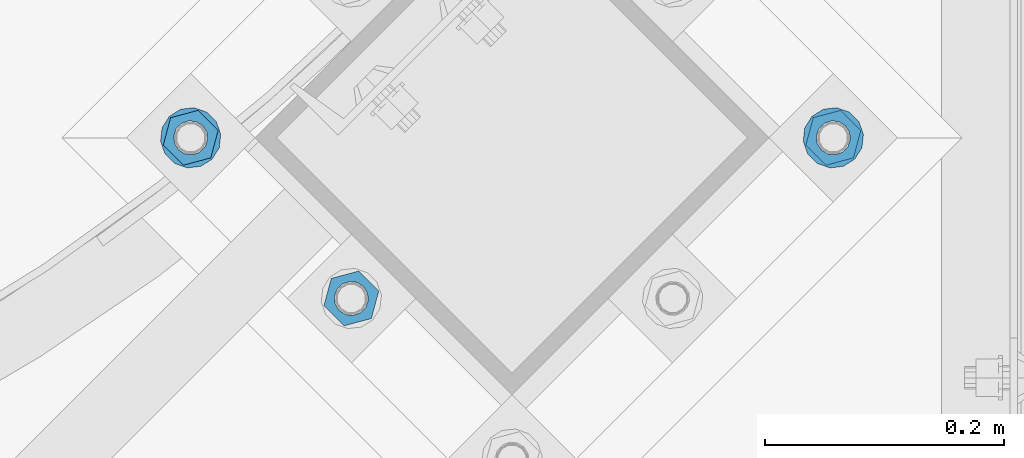
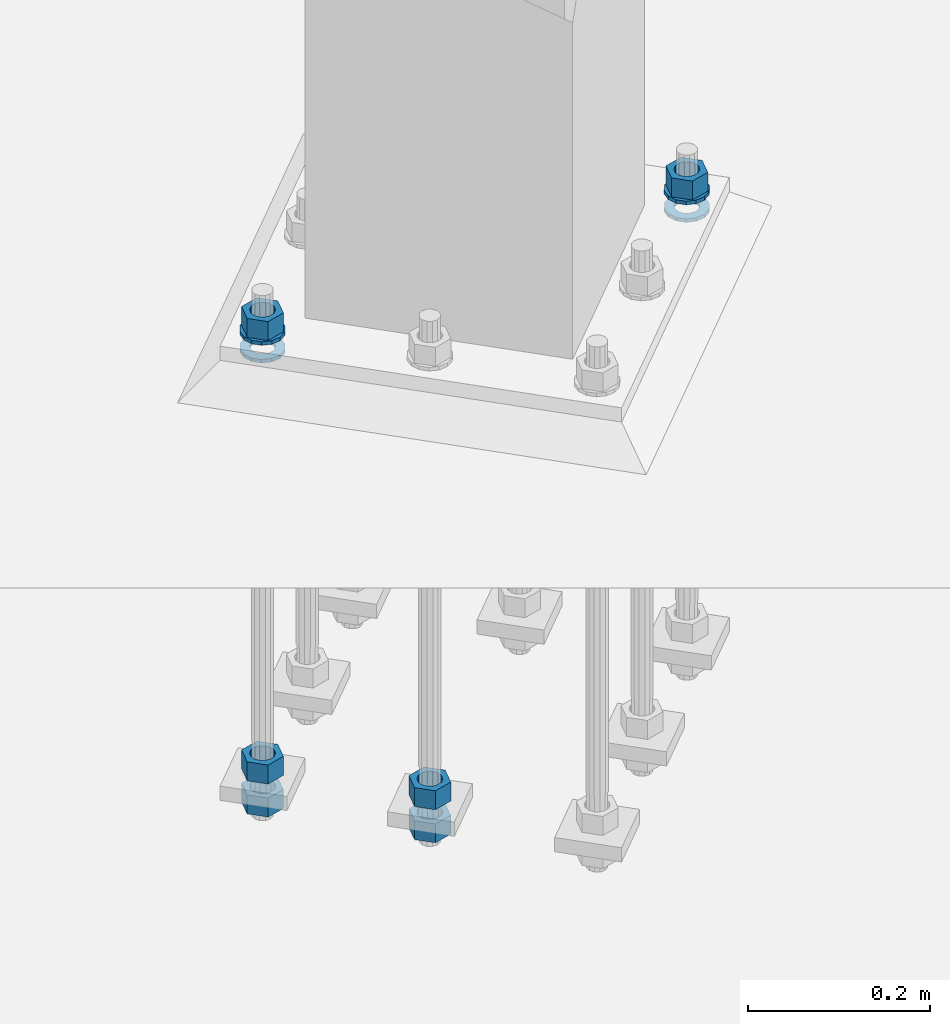
# One storey, part 866 of 1876: 10 columns, 1 element without a shape of its own.
"""IFC2X3 building model written with IfcOpenShell, lengths in millimetres."""

from ifc_helpers import new_model, si_unit, frame, origin_with_axes, place, context, subcontext, project, spatial, faceted_brep, material, type_object, element, aggregate, save


model = new_model("IFC2X3")

# Units and contexts
model_context = context("Model", 3, precision=1e-05, world=origin_with_axes())
body_context = subcontext(model_context, "Body", "Model", "MODEL_VIEW")
ifc_project = project(units=[si_unit("LENGTHUNIT", "METRE", prefix="MILLI"), si_unit("AREAUNIT", "SQUARE_METRE"), si_unit("VOLUMEUNIT", "CUBIC_METRE"), si_unit("MASSUNIT", "GRAM", prefix="KILO"), si_unit("TIMEUNIT", "SECOND"), si_unit("PLANEANGLEUNIT", "RADIAN"), si_unit("SOLIDANGLEUNIT", "STERADIAN"), si_unit("THERMODYNAMICTEMPERATUREUNIT", "DEGREE_CELSIUS"), si_unit("LUMINOUSINTENSITYUNIT", "LUMEN")], contexts=[model_context])

# Site, building, storey
site_placement = place(None, origin_with_axes())
site = spatial("IfcSite", under=ifc_project, at=site_placement, CompositionType="ELEMENT")
building_placement = place(site_placement, origin_with_axes())
building = spatial("IfcBuilding", under=site, at=building_placement, Name="Undefined", CompositionType="ELEMENT")
storey_placement = place(building_placement, origin_with_axes())
storey = spatial("IfcBuildingStorey", under=building, at=storey_placement, Name="Undefined", CompositionType="ELEMENT", Elevation=0.0)

# Assembly, columns
assembly_placement = place(storey_placement, origin_with_axes())
assembly = element("IfcElementAssembly", 1, at=assembly_placement, inside=storey, Name="TEMPLATE", AssemblyPlace="NOTDEFINED", PredefinedType="RIGID_FRAME")
ifc_material_1 = material(Name="STEEL/A563")
column_type_1 = type_object("IfcColumnType", Name="1_HEAVY_HEX_NUT", PredefinedType="NOTDEFINED")
column_1_placement = place(assembly_placement, frame((6849.68257448893, -14987.5323904103, 87.3125), z_axis=(0.707106781186548, 0.707106781186547, 0.0), x_axis=(0.0, 0.0, -1.0)))
column_1 = element("IfcColumn", 2, at=column_1_placement, type_object=column_type_1, material=ifc_material_1, Name="NUT", ObjectType="1_HEAVY_HEX_NUT", context=body_context, shape_type="Brep", body=[
    faceted_brep([(0.0, -23.8099994659442, 9.09494701772928e-13), (0.0, -11.9099998474121, -20.6200008392352), (25.4, -11.9099998474157, -20.6200008392361), (25.4, -23.8099994659478, 0.0), (0.0, 11.9099998474157, -20.620000839237), (25.4, 11.9099998474121, -20.620000839237), (0.0, 23.8099994659478, 9.09494701772928e-13), (25.4, 23.8099994659442, 0.0), (0.0, 11.9099998474157, 20.620000839237), (25.4, 11.9099998474121, 20.620000839237), (0.0, -11.9099998474121, 20.6200008392389), (25.4, -11.9099998474157, 20.6200008392379), (0.0, 1.81898940354586e-12, 14.2899999618567), (0.0, 6.20019861543915, 12.8748450879584), (25.4, 6.20019861543733, 12.8748450879593), (25.4, 0.0, 14.2899999618558), (0.0, 11.1723718546473, 8.90966924477925), (25.4, 11.1723718546436, 8.90966924477925), (0.0, 13.9317198278914, 3.17982413774916), (25.4, 13.9317198278877, 3.17982413775007), (0.0, 13.9317198278914, -3.17982413774644), (25.4, 13.9317198278895, -3.17982413774735), (0.0, 11.1723718546473, -8.90966924477834), (25.4, 11.1723718546455, -8.90966924477925), (0.0, 6.20019861544279, -12.8748450879575), (25.4, 6.20019861543915, -12.8748450879584), (0.0, 3.63797880709171e-12, -14.2899999618548), (25.4, -3.63797880709171e-12, -14.2899999618548), (0.0, -6.20019861543733, -12.8748450879566), (25.4, -6.20019861544097, -12.8748450879584), (0.0, -11.1723718546455, -8.90966924477743), (25.4, -11.1723718546473, -8.90966924477834), (0.0, -13.9317198278877, -3.17982413774735), (25.4, -13.9317198278914, -3.17982413774826), (0.0, -13.9317198278895, 3.17982413774735), (25.4, -13.9317198278914, 3.17982413774826), (0.0, -11.1723718546455, 8.90966924477925), (25.4, -11.1723718546473, 8.90966924478016), (0.0, -6.20019861543915, 12.8748450879593), (25.4, -6.20019861544279, 12.8748450879593)], [[[0, 1, 2, 3]], [[1, 4, 5, 2]], [[4, 6, 7, 5]], [[6, 8, 9, 7]], [[8, 10, 11, 9]], [[10, 0, 3, 11]], [[12, 13, 14, 15]], [[13, 16, 17, 14]], [[16, 18, 19, 17]], [[18, 20, 21, 19]], [[20, 22, 23, 21]], [[22, 24, 25, 23]], [[24, 26, 27, 25]], [[26, 28, 29, 27]], [[28, 30, 31, 29]], [[30, 32, 33, 31]], [[32, 34, 35, 33]], [[34, 36, 37, 35]], [[36, 38, 39, 37]], [[38, 12, 15, 39]], [[5, 7, 9, 11, 3, 2], [17, 19, 21, 23, 25, 27, 29, 31, 33, 35, 37, 39, 15, 14]], [[10, 8, 6, 4, 1, 0], [38, 36, 34, 32, 30, 28, 26, 24, 22, 20, 18, 16, 13, 12]]]),
])
column_2_placement = place(assembly_placement, frame((6445.57104904047, -15122.2362322265, -508.0), z_axis=(0.707106781186548, 0.707106781186547, 0.0), x_axis=(0.0, 0.0, -1.0)))
column_2 = element("IfcColumn", 3, at=column_2_placement, type_object=column_type_1, material=ifc_material_1, Name="NUT", ObjectType="1_HEAVY_HEX_NUT", context=body_context, shape_type="Brep", body=[
    faceted_brep([(0.0, -23.8099994659442, 9.09494701772928e-13), (0.0, -11.9099998474121, -20.6200008392352), (25.4, -11.9099998474157, -20.6200008392361), (25.4, -23.8099994659478, 0.0), (0.0, 11.9099998474157, -20.620000839237), (25.4, 11.9099998474121, -20.620000839237), (0.0, 23.8099994659478, 9.09494701772928e-13), (25.4, 23.8099994659442, 0.0), (0.0, 11.9099998474157, 20.620000839237), (25.4, 11.9099998474121, 20.620000839237), (0.0, -11.9099998474121, 20.6200008392389), (25.4, -11.9099998474157, 20.6200008392379), (0.0, 1.81898940354586e-12, 14.2899999618567), (0.0, 6.20019861543915, 12.8748450879584), (25.4, 6.20019861543733, 12.8748450879593), (25.4, 0.0, 14.2899999618558), (0.0, 11.1723718546473, 8.90966924477925), (25.4, 11.1723718546436, 8.90966924477925), (0.0, 13.9317198278914, 3.17982413774916), (25.4, 13.9317198278877, 3.17982413775007), (0.0, 13.9317198278914, -3.17982413774644), (25.4, 13.9317198278895, -3.17982413774735), (0.0, 11.1723718546473, -8.90966924477834), (25.4, 11.1723718546455, -8.90966924477925), (0.0, 6.20019861544279, -12.8748450879575), (25.4, 6.20019861543915, -12.8748450879584), (0.0, 3.63797880709171e-12, -14.2899999618548), (25.4, -3.63797880709171e-12, -14.2899999618548), (0.0, -6.20019861543733, -12.8748450879566), (25.4, -6.20019861544097, -12.8748450879584), (0.0, -11.1723718546455, -8.90966924477743), (25.4, -11.1723718546473, -8.90966924477834), (0.0, -13.9317198278877, -3.17982413774735), (25.4, -13.9317198278914, -3.17982413774826), (0.0, -13.9317198278895, 3.17982413774735), (25.4, -13.9317198278914, 3.17982413774826), (0.0, -11.1723718546455, 8.90966924477925), (25.4, -11.1723718546473, 8.90966924478016), (0.0, -6.20019861543915, 12.8748450879593), (25.4, -6.20019861544279, 12.8748450879593)], [[[0, 1, 2, 3]], [[1, 4, 5, 2]], [[4, 6, 7, 5]], [[6, 8, 9, 7]], [[8, 10, 11, 9]], [[10, 0, 3, 11]], [[12, 13, 14, 15]], [[13, 16, 17, 14]], [[16, 18, 19, 17]], [[18, 20, 21, 19]], [[20, 22, 23, 21]], [[22, 24, 25, 23]], [[24, 26, 27, 25]], [[26, 28, 29, 27]], [[28, 30, 31, 29]], [[30, 32, 33, 31]], [[32, 34, 35, 33]], [[34, 36, 37, 35]], [[36, 38, 39, 37]], [[38, 12, 15, 39]], [[5, 7, 9, 11, 3, 2], [17, 19, 21, 23, 25, 27, 29, 31, 33, 35, 37, 39, 15, 14]], [[10, 8, 6, 4, 1, 0], [38, 36, 34, 32, 30, 28, 26, 24, 22, 20, 18, 16, 13, 12]]]),
])
column_3_placement = place(assembly_placement, frame((6445.57104904047, -15122.2362322265, -552.45), z_axis=(0.707106781186548, 0.707106781186547, 0.0), x_axis=(0.0, 0.0, -1.0)))
column_3 = element("IfcColumn", 4, at=column_3_placement, type_object=column_type_1, material=ifc_material_1, Name="NUT", ObjectType="1_HEAVY_HEX_NUT", context=body_context, shape_type="Brep", body=[
    faceted_brep([(0.0, -23.8099994659442, 9.09494701772928e-13), (0.0, -11.9099998474121, -20.6200008392352), (25.4, -11.9099998474157, -20.6200008392361), (25.4, -23.8099994659478, 0.0), (0.0, 11.9099998474157, -20.620000839237), (25.4, 11.9099998474121, -20.620000839237), (0.0, 23.8099994659478, 9.09494701772928e-13), (25.4, 23.8099994659442, 0.0), (0.0, 11.9099998474157, 20.620000839237), (25.4, 11.9099998474121, 20.620000839237), (0.0, -11.9099998474121, 20.6200008392389), (25.4, -11.9099998474157, 20.6200008392379), (0.0, 1.81898940354586e-12, 14.2899999618567), (0.0, 6.20019861543915, 12.8748450879584), (25.4, 6.20019861543733, 12.8748450879593), (25.4, 0.0, 14.2899999618558), (0.0, 11.1723718546473, 8.90966924477925), (25.4, 11.1723718546436, 8.90966924477925), (0.0, 13.9317198278914, 3.17982413774916), (25.4, 13.9317198278877, 3.17982413775007), (0.0, 13.9317198278914, -3.17982413774644), (25.4, 13.9317198278895, -3.17982413774735), (0.0, 11.1723718546473, -8.90966924477834), (25.4, 11.1723718546455, -8.90966924477925), (0.0, 6.20019861544279, -12.8748450879575), (25.4, 6.20019861543915, -12.8748450879584), (0.0, 3.63797880709171e-12, -14.2899999618548), (25.4, -3.63797880709171e-12, -14.2899999618548), (0.0, -6.20019861543733, -12.8748450879566), (25.4, -6.20019861544097, -12.8748450879584), (0.0, -11.1723718546455, -8.90966924477743), (25.4, -11.1723718546473, -8.90966924477834), (0.0, -13.9317198278877, -3.17982413774735), (25.4, -13.9317198278914, -3.17982413774826), (0.0, -13.9317198278895, 3.17982413774735), (25.4, -13.9317198278914, 3.17982413774826), (0.0, -11.1723718546455, 8.90966924477925), (25.4, -11.1723718546473, 8.90966924478016), (0.0, -6.20019861543915, 12.8748450879593), (25.4, -6.20019861544279, 12.8748450879593)], [[[0, 1, 2, 3]], [[1, 4, 5, 2]], [[4, 6, 7, 5]], [[6, 8, 9, 7]], [[8, 10, 11, 9]], [[10, 0, 3, 11]], [[12, 13, 14, 15]], [[13, 16, 17, 14]], [[16, 18, 19, 17]], [[18, 20, 21, 19]], [[20, 22, 23, 21]], [[22, 24, 25, 23]], [[24, 26, 27, 25]], [[26, 28, 29, 27]], [[28, 30, 31, 29]], [[30, 32, 33, 31]], [[32, 34, 35, 33]], [[34, 36, 37, 35]], [[36, 38, 39, 37]], [[38, 12, 15, 39]], [[5, 7, 9, 11, 3, 2], [17, 19, 21, 23, 25, 27, 29, 31, 33, 35, 37, 39, 15, 14]], [[10, 8, 6, 4, 1, 0], [38, 36, 34, 32, 30, 28, 26, 24, 22, 20, 18, 16, 13, 12]]]),
])
column_4_placement = place(assembly_placement, frame((6310.86720722432, -14987.5323904103, 87.3125), z_axis=(-0.707106781186547, -0.707106781186548, 0.0), x_axis=(0.0, 0.0, -1.0)))
column_4 = element("IfcColumn", 5, at=column_4_placement, type_object=column_type_1, material=ifc_material_1, Name="NUT", ObjectType="1_HEAVY_HEX_NUT", context=body_context, shape_type="Brep", body=[
    faceted_brep([(0.0, -23.8099994659442, 9.09494701772928e-13), (0.0, -11.9099998474121, -20.6200008392352), (25.4, -11.9099998474157, -20.6200008392361), (25.4, -23.8099994659478, 0.0), (0.0, 11.9099998474157, -20.620000839237), (25.4, 11.9099998474121, -20.620000839237), (0.0, 23.8099994659478, 9.09494701772928e-13), (25.4, 23.8099994659442, 0.0), (0.0, 11.9099998474157, 20.620000839237), (25.4, 11.9099998474121, 20.620000839237), (0.0, -11.9099998474121, 20.6200008392389), (25.4, -11.9099998474157, 20.6200008392379), (0.0, 1.81898940354586e-12, 14.2899999618567), (0.0, 6.20019861543915, 12.8748450879584), (25.4, 6.20019861543733, 12.8748450879593), (25.4, 0.0, 14.2899999618558), (0.0, 11.1723718546473, 8.90966924477925), (25.4, 11.1723718546436, 8.90966924477925), (0.0, 13.9317198278914, 3.17982413774916), (25.4, 13.9317198278877, 3.17982413775007), (0.0, 13.9317198278914, -3.17982413774644), (25.4, 13.9317198278895, -3.17982413774735), (0.0, 11.1723718546473, -8.90966924477834), (25.4, 11.1723718546455, -8.90966924477925), (0.0, 6.20019861544279, -12.8748450879575), (25.4, 6.20019861543915, -12.8748450879584), (0.0, 3.63797880709171e-12, -14.2899999618548), (25.4, -3.63797880709171e-12, -14.2899999618548), (0.0, -6.20019861543733, -12.8748450879566), (25.4, -6.20019861544097, -12.8748450879584), (0.0, -11.1723718546455, -8.90966924477743), (25.4, -11.1723718546473, -8.90966924477834), (0.0, -13.9317198278877, -3.17982413774735), (25.4, -13.9317198278914, -3.17982413774826), (0.0, -13.9317198278895, 3.17982413774735), (25.4, -13.9317198278914, 3.17982413774826), (0.0, -11.1723718546455, 8.90966924477925), (25.4, -11.1723718546473, 8.90966924478016), (0.0, -6.20019861543915, 12.8748450879593), (25.4, -6.20019861544279, 12.8748450879593)], [[[0, 1, 2, 3]], [[1, 4, 5, 2]], [[4, 6, 7, 5]], [[6, 8, 9, 7]], [[8, 10, 11, 9]], [[10, 0, 3, 11]], [[12, 13, 14, 15]], [[13, 16, 17, 14]], [[16, 18, 19, 17]], [[18, 20, 21, 19]], [[20, 22, 23, 21]], [[22, 24, 25, 23]], [[24, 26, 27, 25]], [[26, 28, 29, 27]], [[28, 30, 31, 29]], [[30, 32, 33, 31]], [[32, 34, 35, 33]], [[34, 36, 37, 35]], [[36, 38, 39, 37]], [[38, 12, 15, 39]], [[5, 7, 9, 11, 3, 2], [17, 19, 21, 23, 25, 27, 29, 31, 33, 35, 37, 39, 15, 14]], [[10, 8, 6, 4, 1, 0], [38, 36, 34, 32, 30, 28, 26, 24, 22, 20, 18, 16, 13, 12]]]),
])
column_5_placement = place(assembly_placement, frame((6310.86720722432, -14987.5323904103, -508.0), z_axis=(-0.707106781186547, -0.707106781186548, 0.0), x_axis=(0.0, 0.0, -1.0)))
column_5 = element("IfcColumn", 6, at=column_5_placement, type_object=column_type_1, material=ifc_material_1, Name="NUT", ObjectType="1_HEAVY_HEX_NUT", context=body_context, shape_type="Brep", body=[
    faceted_brep([(0.0, -23.8099994659442, 9.09494701772928e-13), (0.0, -11.9099998474121, -20.6200008392352), (25.4, -11.9099998474157, -20.6200008392361), (25.4, -23.8099994659478, 0.0), (0.0, 11.9099998474157, -20.620000839237), (25.4, 11.9099998474121, -20.620000839237), (0.0, 23.8099994659478, 9.09494701772928e-13), (25.4, 23.8099994659442, 0.0), (0.0, 11.9099998474157, 20.620000839237), (25.4, 11.9099998474121, 20.620000839237), (0.0, -11.9099998474121, 20.6200008392389), (25.4, -11.9099998474157, 20.6200008392379), (0.0, 1.81898940354586e-12, 14.2899999618567), (0.0, 6.20019861543915, 12.8748450879584), (25.4, 6.20019861543733, 12.8748450879593), (25.4, 0.0, 14.2899999618558), (0.0, 11.1723718546473, 8.90966924477925), (25.4, 11.1723718546436, 8.90966924477925), (0.0, 13.9317198278914, 3.17982413774916), (25.4, 13.9317198278877, 3.17982413775007), (0.0, 13.9317198278914, -3.17982413774644), (25.4, 13.9317198278895, -3.17982413774735), (0.0, 11.1723718546473, -8.90966924477834), (25.4, 11.1723718546455, -8.90966924477925), (0.0, 6.20019861544279, -12.8748450879575), (25.4, 6.20019861543915, -12.8748450879584), (0.0, 3.63797880709171e-12, -14.2899999618548), (25.4, -3.63797880709171e-12, -14.2899999618548), (0.0, -6.20019861543733, -12.8748450879566), (25.4, -6.20019861544097, -12.8748450879584), (0.0, -11.1723718546455, -8.90966924477743), (25.4, -11.1723718546473, -8.90966924477834), (0.0, -13.9317198278877, -3.17982413774735), (25.4, -13.9317198278914, -3.17982413774826), (0.0, -13.9317198278895, 3.17982413774735), (25.4, -13.9317198278914, 3.17982413774826), (0.0, -11.1723718546455, 8.90966924477925), (25.4, -11.1723718546473, 8.90966924478016), (0.0, -6.20019861543915, 12.8748450879593), (25.4, -6.20019861544279, 12.8748450879593)], [[[0, 1, 2, 3]], [[1, 4, 5, 2]], [[4, 6, 7, 5]], [[6, 8, 9, 7]], [[8, 10, 11, 9]], [[10, 0, 3, 11]], [[12, 13, 14, 15]], [[13, 16, 17, 14]], [[16, 18, 19, 17]], [[18, 20, 21, 19]], [[20, 22, 23, 21]], [[22, 24, 25, 23]], [[24, 26, 27, 25]], [[26, 28, 29, 27]], [[28, 30, 31, 29]], [[30, 32, 33, 31]], [[32, 34, 35, 33]], [[34, 36, 37, 35]], [[36, 38, 39, 37]], [[38, 12, 15, 39]], [[5, 7, 9, 11, 3, 2], [17, 19, 21, 23, 25, 27, 29, 31, 33, 35, 37, 39, 15, 14]], [[10, 8, 6, 4, 1, 0], [38, 36, 34, 32, 30, 28, 26, 24, 22, 20, 18, 16, 13, 12]]]),
])
column_6_placement = place(assembly_placement, frame((6310.86720722432, -14987.5323904103, -552.45), z_axis=(-0.707106781186547, -0.707106781186548, 0.0), x_axis=(0.0, 0.0, -1.0)))
column_6 = element("IfcColumn", 7, at=column_6_placement, type_object=column_type_1, material=ifc_material_1, Name="NUT", ObjectType="1_HEAVY_HEX_NUT", context=body_context, shape_type="Brep", body=[
    faceted_brep([(0.0, -23.8099994659442, 9.09494701772928e-13), (0.0, -11.9099998474121, -20.6200008392352), (25.4, -11.9099998474157, -20.6200008392361), (25.4, -23.8099994659478, 0.0), (0.0, 11.9099998474157, -20.620000839237), (25.4, 11.9099998474121, -20.620000839237), (0.0, 23.8099994659478, 9.09494701772928e-13), (25.4, 23.8099994659442, 0.0), (0.0, 11.9099998474157, 20.620000839237), (25.4, 11.9099998474121, 20.620000839237), (0.0, -11.9099998474121, 20.6200008392389), (25.4, -11.9099998474157, 20.6200008392379), (0.0, 1.81898940354586e-12, 14.2899999618567), (0.0, 6.20019861543915, 12.8748450879584), (25.4, 6.20019861543733, 12.8748450879593), (25.4, 0.0, 14.2899999618558), (0.0, 11.1723718546473, 8.90966924477925), (25.4, 11.1723718546436, 8.90966924477925), (0.0, 13.9317198278914, 3.17982413774916), (25.4, 13.9317198278877, 3.17982413775007), (0.0, 13.9317198278914, -3.17982413774644), (25.4, 13.9317198278895, -3.17982413774735), (0.0, 11.1723718546473, -8.90966924477834), (25.4, 11.1723718546455, -8.90966924477925), (0.0, 6.20019861544279, -12.8748450879575), (25.4, 6.20019861543915, -12.8748450879584), (0.0, 3.63797880709171e-12, -14.2899999618548), (25.4, -3.63797880709171e-12, -14.2899999618548), (0.0, -6.20019861543733, -12.8748450879566), (25.4, -6.20019861544097, -12.8748450879584), (0.0, -11.1723718546455, -8.90966924477743), (25.4, -11.1723718546473, -8.90966924477834), (0.0, -13.9317198278877, -3.17982413774735), (25.4, -13.9317198278914, -3.17982413774826), (0.0, -13.9317198278895, 3.17982413774735), (25.4, -13.9317198278914, 3.17982413774826), (0.0, -11.1723718546455, 8.90966924477925), (25.4, -11.1723718546473, 8.90966924478016), (0.0, -6.20019861543915, 12.8748450879593), (25.4, -6.20019861544279, 12.8748450879593)], [[[0, 1, 2, 3]], [[1, 4, 5, 2]], [[4, 6, 7, 5]], [[6, 8, 9, 7]], [[8, 10, 11, 9]], [[10, 0, 3, 11]], [[12, 13, 14, 15]], [[13, 16, 17, 14]], [[16, 18, 19, 17]], [[18, 20, 21, 19]], [[20, 22, 23, 21]], [[22, 24, 25, 23]], [[24, 26, 27, 25]], [[26, 28, 29, 27]], [[28, 30, 31, 29]], [[30, 32, 33, 31]], [[32, 34, 35, 33]], [[34, 36, 37, 35]], [[36, 38, 39, 37]], [[38, 12, 15, 39]], [[5, 7, 9, 11, 3, 2], [17, 19, 21, 23, 25, 27, 29, 31, 33, 35, 37, 39, 15, 14]], [[10, 8, 6, 4, 1, 0], [38, 36, 34, 32, 30, 28, 26, 24, 22, 20, 18, 16, 13, 12]]]),
])
ifc_material_2 = material(Name="STEEL/F436")
column_type_2 = type_object("IfcColumnType", Name="1_WASHER", PredefinedType="NOTDEFINED")
column_7_placement = place(assembly_placement, frame((6849.68257448893, -14987.5323904103, 38.1), z_axis=(0.707106781186548, 0.707106781186547, 0.0), x_axis=(0.0, 0.0, -1.0)))
column_7 = element("IfcColumn", 8, at=column_7_placement, type_object=column_type_2, material=ifc_material_2, Name="WASHER", ObjectType="1_WASHER", context=body_context, shape_type="Brep", body=[
    faceted_brep([(0.0, -25.3999996185375, 0.0), (0.0, -22.8846089010331, -11.0206468080742), (4.7625, -22.8846089010331, -11.0206468080742), (4.7625, -25.3999996185375, 0.0), (0.0, -15.8366407293743, -19.8585193564477), (4.7625, -15.8366407293743, -19.8585193564477), (0.0, -5.65203163760816, -24.7631685975166), (4.7625, -5.65203163760816, -24.7631685975166), (0.0, 5.65203163760452, -24.7631685975166), (4.7625, 5.65203163760452, -24.7631685975166), (0.0, 15.8366407293706, -19.858519356445), (4.7625, 15.8366407293706, -19.858519356445), (0.0, 22.8846089010331, -11.0206468080733), (4.7625, 22.8846089010331, -11.0206468080733), (0.0, 25.3999996185339, 9.09494701772928e-13), (4.7625, 25.3999996185339, 9.09494701772928e-13), (0.0, 22.8846089010331, 11.0206468080751), (4.7625, 22.8846089010331, 11.0206468080751), (0.0, 15.8366407293706, 19.8585193564486), (4.7625, 15.8366407293706, 19.8585193564486), (0.0, 5.65203163760452, 24.7631685975175), (4.7625, 5.65203163760452, 24.7631685975175), (0.0, -5.65203163760816, 24.7631685975175), (4.7625, -5.65203163760816, 24.7631685975175), (0.0, -15.8366407293724, 19.8585193564459), (4.7625, -15.8366407293724, 19.8585193564459), (0.0, -22.8846089010367, 11.0206468080751), (4.7625, -22.8846089010367, 11.0206468080751), (0.0, 1.81898940354586e-12, 14.2899999618567), (0.0, 6.20019861543915, 12.8748450879584), (4.7625, 6.20019861543733, 12.8748450879593), (4.7625, 0.0, 14.2899999618558), (0.0, 11.1723718546473, 8.90966924477925), (4.7625, 11.1723718546436, 8.90966924477925), (0.0, 13.9317198278914, 3.17982413774916), (4.7625, 13.9317198278877, 3.17982413775007), (0.0, 13.9317198278914, -3.17982413774644), (4.7625, 13.9317198278895, -3.17982413774735), (0.0, 11.1723718546473, -8.90966924477834), (4.7625, 11.1723718546455, -8.90966924477925), (0.0, 6.20019861544279, -12.8748450879575), (4.7625, 6.20019861543915, -12.8748450879584), (0.0, 3.63797880709171e-12, -14.2899999618548), (4.7625, -3.63797880709171e-12, -14.2899999618548), (0.0, -6.20019861543733, -12.8748450879566), (4.7625, -6.20019861544097, -12.8748450879584), (0.0, -11.1723718546455, -8.90966924477743), (4.7625, -11.1723718546473, -8.90966924477834), (0.0, -13.9317198278877, -3.17982413774735), (4.7625, -13.9317198278914, -3.17982413774826), (0.0, -13.9317198278895, 3.17982413774735), (4.7625, -13.9317198278914, 3.17982413774826), (0.0, -11.1723718546455, 8.90966924477925), (4.7625, -11.1723718546473, 8.90966924478016), (0.0, -6.20019861543915, 12.8748450879593), (4.7625, -6.20019861544279, 12.8748450879593)], [[[0, 1, 2, 3]], [[1, 4, 5, 2]], [[4, 6, 7, 5]], [[6, 8, 9, 7]], [[8, 10, 11, 9]], [[10, 12, 13, 11]], [[12, 14, 15, 13]], [[14, 16, 17, 15]], [[16, 18, 19, 17]], [[18, 20, 21, 19]], [[20, 22, 23, 21]], [[22, 24, 25, 23]], [[24, 26, 27, 25]], [[26, 0, 3, 27]], [[28, 29, 30, 31]], [[29, 32, 33, 30]], [[32, 34, 35, 33]], [[34, 36, 37, 35]], [[36, 38, 39, 37]], [[38, 40, 41, 39]], [[40, 42, 43, 41]], [[42, 44, 45, 43]], [[44, 46, 47, 45]], [[46, 48, 49, 47]], [[48, 50, 51, 49]], [[50, 52, 53, 51]], [[52, 54, 55, 53]], [[54, 28, 31, 55]], [[5, 7, 9, 11, 13, 15, 17, 19, 21, 23, 25, 27, 3, 2], [33, 35, 37, 39, 41, 43, 45, 47, 49, 51, 53, 55, 31, 30]], [[26, 24, 22, 20, 18, 16, 14, 12, 10, 8, 6, 4, 1, 0], [54, 52, 50, 48, 46, 44, 42, 40, 38, 36, 34, 32, 29, 28]]]),
])
column_8_placement = place(assembly_placement, frame((6849.68257448893, -14987.5323904103, 61.9125), z_axis=(0.707106781186548, 0.707106781186547, 0.0), x_axis=(0.0, 0.0, -1.0)))
column_8 = element("IfcColumn", 9, at=column_8_placement, type_object=column_type_2, material=ifc_material_2, Name="WASHER", ObjectType="1_WASHER", context=body_context, shape_type="Brep", body=[
    faceted_brep([(0.0, -25.3999996185375, 0.0), (0.0, -22.8846089010331, -11.0206468080742), (4.7625, -22.8846089010331, -11.0206468080742), (4.7625, -25.3999996185375, 0.0), (0.0, -15.8366407293743, -19.8585193564477), (4.7625, -15.8366407293743, -19.8585193564477), (0.0, -5.65203163760816, -24.7631685975166), (4.7625, -5.65203163760816, -24.7631685975166), (0.0, 5.65203163760452, -24.7631685975166), (4.7625, 5.65203163760452, -24.7631685975166), (0.0, 15.8366407293706, -19.858519356445), (4.7625, 15.8366407293706, -19.858519356445), (0.0, 22.8846089010331, -11.0206468080733), (4.7625, 22.8846089010331, -11.0206468080733), (0.0, 25.3999996185339, 9.09494701772928e-13), (4.7625, 25.3999996185339, 9.09494701772928e-13), (0.0, 22.8846089010331, 11.0206468080751), (4.7625, 22.8846089010331, 11.0206468080751), (0.0, 15.8366407293706, 19.8585193564486), (4.7625, 15.8366407293706, 19.8585193564486), (0.0, 5.65203163760452, 24.7631685975175), (4.7625, 5.65203163760452, 24.7631685975175), (0.0, -5.65203163760816, 24.7631685975175), (4.7625, -5.65203163760816, 24.7631685975175), (0.0, -15.8366407293724, 19.8585193564459), (4.7625, -15.8366407293724, 19.8585193564459), (0.0, -22.8846089010367, 11.0206468080751), (4.7625, -22.8846089010367, 11.0206468080751), (0.0, 1.81898940354586e-12, 14.2899999618567), (0.0, 6.20019861543915, 12.8748450879584), (4.7625, 6.20019861543733, 12.8748450879593), (4.7625, 0.0, 14.2899999618558), (0.0, 11.1723718546473, 8.90966924477925), (4.7625, 11.1723718546436, 8.90966924477925), (0.0, 13.9317198278914, 3.17982413774916), (4.7625, 13.9317198278877, 3.17982413775007), (0.0, 13.9317198278914, -3.17982413774644), (4.7625, 13.9317198278895, -3.17982413774735), (0.0, 11.1723718546473, -8.90966924477834), (4.7625, 11.1723718546455, -8.90966924477925), (0.0, 6.20019861544279, -12.8748450879575), (4.7625, 6.20019861543915, -12.8748450879584), (0.0, 3.63797880709171e-12, -14.2899999618548), (4.7625, -3.63797880709171e-12, -14.2899999618548), (0.0, -6.20019861543733, -12.8748450879566), (4.7625, -6.20019861544097, -12.8748450879584), (0.0, -11.1723718546455, -8.90966924477743), (4.7625, -11.1723718546473, -8.90966924477834), (0.0, -13.9317198278877, -3.17982413774735), (4.7625, -13.9317198278914, -3.17982413774826), (0.0, -13.9317198278895, 3.17982413774735), (4.7625, -13.9317198278914, 3.17982413774826), (0.0, -11.1723718546455, 8.90966924477925), (4.7625, -11.1723718546473, 8.90966924478016), (0.0, -6.20019861543915, 12.8748450879593), (4.7625, -6.20019861544279, 12.8748450879593)], [[[0, 1, 2, 3]], [[1, 4, 5, 2]], [[4, 6, 7, 5]], [[6, 8, 9, 7]], [[8, 10, 11, 9]], [[10, 12, 13, 11]], [[12, 14, 15, 13]], [[14, 16, 17, 15]], [[16, 18, 19, 17]], [[18, 20, 21, 19]], [[20, 22, 23, 21]], [[22, 24, 25, 23]], [[24, 26, 27, 25]], [[26, 0, 3, 27]], [[28, 29, 30, 31]], [[29, 32, 33, 30]], [[32, 34, 35, 33]], [[34, 36, 37, 35]], [[36, 38, 39, 37]], [[38, 40, 41, 39]], [[40, 42, 43, 41]], [[42, 44, 45, 43]], [[44, 46, 47, 45]], [[46, 48, 49, 47]], [[48, 50, 51, 49]], [[50, 52, 53, 51]], [[52, 54, 55, 53]], [[54, 28, 31, 55]], [[5, 7, 9, 11, 13, 15, 17, 19, 21, 23, 25, 27, 3, 2], [33, 35, 37, 39, 41, 43, 45, 47, 49, 51, 53, 55, 31, 30]], [[26, 24, 22, 20, 18, 16, 14, 12, 10, 8, 6, 4, 1, 0], [54, 52, 50, 48, 46, 44, 42, 40, 38, 36, 34, 32, 29, 28]]]),
])
column_9_placement = place(assembly_placement, frame((6310.86720722432, -14987.5323904103, 38.1), z_axis=(-0.707106781186547, -0.707106781186548, 0.0), x_axis=(0.0, 0.0, -1.0)))
column_9 = element("IfcColumn", 10, at=column_9_placement, type_object=column_type_2, material=ifc_material_2, Name="WASHER", ObjectType="1_WASHER", context=body_context, shape_type="Brep", body=[
    faceted_brep([(0.0, -25.3999996185375, 0.0), (0.0, -22.8846089010331, -11.0206468080742), (4.7625, -22.8846089010331, -11.0206468080742), (4.7625, -25.3999996185375, 0.0), (0.0, -15.8366407293743, -19.8585193564477), (4.7625, -15.8366407293743, -19.8585193564477), (0.0, -5.65203163760816, -24.7631685975166), (4.7625, -5.65203163760816, -24.7631685975166), (0.0, 5.65203163760452, -24.7631685975166), (4.7625, 5.65203163760452, -24.7631685975166), (0.0, 15.8366407293706, -19.858519356445), (4.7625, 15.8366407293706, -19.858519356445), (0.0, 22.8846089010331, -11.0206468080733), (4.7625, 22.8846089010331, -11.0206468080733), (0.0, 25.3999996185339, 9.09494701772928e-13), (4.7625, 25.3999996185339, 9.09494701772928e-13), (0.0, 22.8846089010331, 11.0206468080751), (4.7625, 22.8846089010331, 11.0206468080751), (0.0, 15.8366407293706, 19.8585193564486), (4.7625, 15.8366407293706, 19.8585193564486), (0.0, 5.65203163760452, 24.7631685975175), (4.7625, 5.65203163760452, 24.7631685975175), (0.0, -5.65203163760816, 24.7631685975175), (4.7625, -5.65203163760816, 24.7631685975175), (0.0, -15.8366407293724, 19.8585193564459), (4.7625, -15.8366407293724, 19.8585193564459), (0.0, -22.8846089010367, 11.0206468080751), (4.7625, -22.8846089010367, 11.0206468080751), (0.0, 1.81898940354586e-12, 14.2899999618567), (0.0, 6.20019861543915, 12.8748450879584), (4.7625, 6.20019861543733, 12.8748450879593), (4.7625, 0.0, 14.2899999618558), (0.0, 11.1723718546473, 8.90966924477925), (4.7625, 11.1723718546436, 8.90966924477925), (0.0, 13.9317198278914, 3.17982413774916), (4.7625, 13.9317198278877, 3.17982413775007), (0.0, 13.9317198278914, -3.17982413774644), (4.7625, 13.9317198278895, -3.17982413774735), (0.0, 11.1723718546473, -8.90966924477834), (4.7625, 11.1723718546455, -8.90966924477925), (0.0, 6.20019861544279, -12.8748450879575), (4.7625, 6.20019861543915, -12.8748450879584), (0.0, 3.63797880709171e-12, -14.2899999618548), (4.7625, -3.63797880709171e-12, -14.2899999618548), (0.0, -6.20019861543733, -12.8748450879566), (4.7625, -6.20019861544097, -12.8748450879584), (0.0, -11.1723718546455, -8.90966924477743), (4.7625, -11.1723718546473, -8.90966924477834), (0.0, -13.9317198278877, -3.17982413774735), (4.7625, -13.9317198278914, -3.17982413774826), (0.0, -13.9317198278895, 3.17982413774735), (4.7625, -13.9317198278914, 3.17982413774826), (0.0, -11.1723718546455, 8.90966924477925), (4.7625, -11.1723718546473, 8.90966924478016), (0.0, -6.20019861543915, 12.8748450879593), (4.7625, -6.20019861544279, 12.8748450879593)], [[[0, 1, 2, 3]], [[1, 4, 5, 2]], [[4, 6, 7, 5]], [[6, 8, 9, 7]], [[8, 10, 11, 9]], [[10, 12, 13, 11]], [[12, 14, 15, 13]], [[14, 16, 17, 15]], [[16, 18, 19, 17]], [[18, 20, 21, 19]], [[20, 22, 23, 21]], [[22, 24, 25, 23]], [[24, 26, 27, 25]], [[26, 0, 3, 27]], [[28, 29, 30, 31]], [[29, 32, 33, 30]], [[32, 34, 35, 33]], [[34, 36, 37, 35]], [[36, 38, 39, 37]], [[38, 40, 41, 39]], [[40, 42, 43, 41]], [[42, 44, 45, 43]], [[44, 46, 47, 45]], [[46, 48, 49, 47]], [[48, 50, 51, 49]], [[50, 52, 53, 51]], [[52, 54, 55, 53]], [[54, 28, 31, 55]], [[5, 7, 9, 11, 13, 15, 17, 19, 21, 23, 25, 27, 3, 2], [33, 35, 37, 39, 41, 43, 45, 47, 49, 51, 53, 55, 31, 30]], [[26, 24, 22, 20, 18, 16, 14, 12, 10, 8, 6, 4, 1, 0], [54, 52, 50, 48, 46, 44, 42, 40, 38, 36, 34, 32, 29, 28]]]),
])
column_10_placement = place(assembly_placement, frame((6310.86720722432, -14987.5323904103, 61.9125), z_axis=(-0.707106781186547, -0.707106781186548, 0.0), x_axis=(0.0, 0.0, -1.0)))
column_10 = element("IfcColumn", 11, at=column_10_placement, type_object=column_type_2, material=ifc_material_2, Name="WASHER", ObjectType="1_WASHER", context=body_context, shape_type="Brep", body=[
    faceted_brep([(0.0, -25.3999996185375, 0.0), (0.0, -22.8846089010331, -11.0206468080742), (4.7625, -22.8846089010331, -11.0206468080742), (4.7625, -25.3999996185375, 0.0), (0.0, -15.8366407293743, -19.8585193564477), (4.7625, -15.8366407293743, -19.8585193564477), (0.0, -5.65203163760816, -24.7631685975166), (4.7625, -5.65203163760816, -24.7631685975166), (0.0, 5.65203163760452, -24.7631685975166), (4.7625, 5.65203163760452, -24.7631685975166), (0.0, 15.8366407293706, -19.858519356445), (4.7625, 15.8366407293706, -19.858519356445), (0.0, 22.8846089010331, -11.0206468080733), (4.7625, 22.8846089010331, -11.0206468080733), (0.0, 25.3999996185339, 9.09494701772928e-13), (4.7625, 25.3999996185339, 9.09494701772928e-13), (0.0, 22.8846089010331, 11.0206468080751), (4.7625, 22.8846089010331, 11.0206468080751), (0.0, 15.8366407293706, 19.8585193564486), (4.7625, 15.8366407293706, 19.8585193564486), (0.0, 5.65203163760452, 24.7631685975175), (4.7625, 5.65203163760452, 24.7631685975175), (0.0, -5.65203163760816, 24.7631685975175), (4.7625, -5.65203163760816, 24.7631685975175), (0.0, -15.8366407293724, 19.8585193564459), (4.7625, -15.8366407293724, 19.8585193564459), (0.0, -22.8846089010367, 11.0206468080751), (4.7625, -22.8846089010367, 11.0206468080751), (0.0, 1.81898940354586e-12, 14.2899999618567), (0.0, 6.20019861543915, 12.8748450879584), (4.7625, 6.20019861543733, 12.8748450879593), (4.7625, 0.0, 14.2899999618558), (0.0, 11.1723718546473, 8.90966924477925), (4.7625, 11.1723718546436, 8.90966924477925), (0.0, 13.9317198278914, 3.17982413774916), (4.7625, 13.9317198278877, 3.17982413775007), (0.0, 13.9317198278914, -3.17982413774644), (4.7625, 13.9317198278895, -3.17982413774735), (0.0, 11.1723718546473, -8.90966924477834), (4.7625, 11.1723718546455, -8.90966924477925), (0.0, 6.20019861544279, -12.8748450879575), (4.7625, 6.20019861543915, -12.8748450879584), (0.0, 3.63797880709171e-12, -14.2899999618548), (4.7625, -3.63797880709171e-12, -14.2899999618548), (0.0, -6.20019861543733, -12.8748450879566), (4.7625, -6.20019861544097, -12.8748450879584), (0.0, -11.1723718546455, -8.90966924477743), (4.7625, -11.1723718546473, -8.90966924477834), (0.0, -13.9317198278877, -3.17982413774735), (4.7625, -13.9317198278914, -3.17982413774826), (0.0, -13.9317198278895, 3.17982413774735), (4.7625, -13.9317198278914, 3.17982413774826), (0.0, -11.1723718546455, 8.90966924477925), (4.7625, -11.1723718546473, 8.90966924478016), (0.0, -6.20019861543915, 12.8748450879593), (4.7625, -6.20019861544279, 12.8748450879593)], [[[0, 1, 2, 3]], [[1, 4, 5, 2]], [[4, 6, 7, 5]], [[6, 8, 9, 7]], [[8, 10, 11, 9]], [[10, 12, 13, 11]], [[12, 14, 15, 13]], [[14, 16, 17, 15]], [[16, 18, 19, 17]], [[18, 20, 21, 19]], [[20, 22, 23, 21]], [[22, 24, 25, 23]], [[24, 26, 27, 25]], [[26, 0, 3, 27]], [[28, 29, 30, 31]], [[29, 32, 33, 30]], [[32, 34, 35, 33]], [[34, 36, 37, 35]], [[36, 38, 39, 37]], [[38, 40, 41, 39]], [[40, 42, 43, 41]], [[42, 44, 45, 43]], [[44, 46, 47, 45]], [[46, 48, 49, 47]], [[48, 50, 51, 49]], [[50, 52, 53, 51]], [[52, 54, 55, 53]], [[54, 28, 31, 55]], [[5, 7, 9, 11, 13, 15, 17, 19, 21, 23, 25, 27, 3, 2], [33, 35, 37, 39, 41, 43, 45, 47, 49, 51, 53, 55, 31, 30]], [[26, 24, 22, 20, 18, 16, 14, 12, 10, 8, 6, 4, 1, 0], [54, 52, 50, 48, 46, 44, 42, 40, 38, 36, 34, 32, 29, 28]]]),
])
aggregate(assembly, [column_1, column_7, column_8, column_2, column_3, column_4, column_9, column_10, column_5, column_6])

save(model, "model.ifc")
